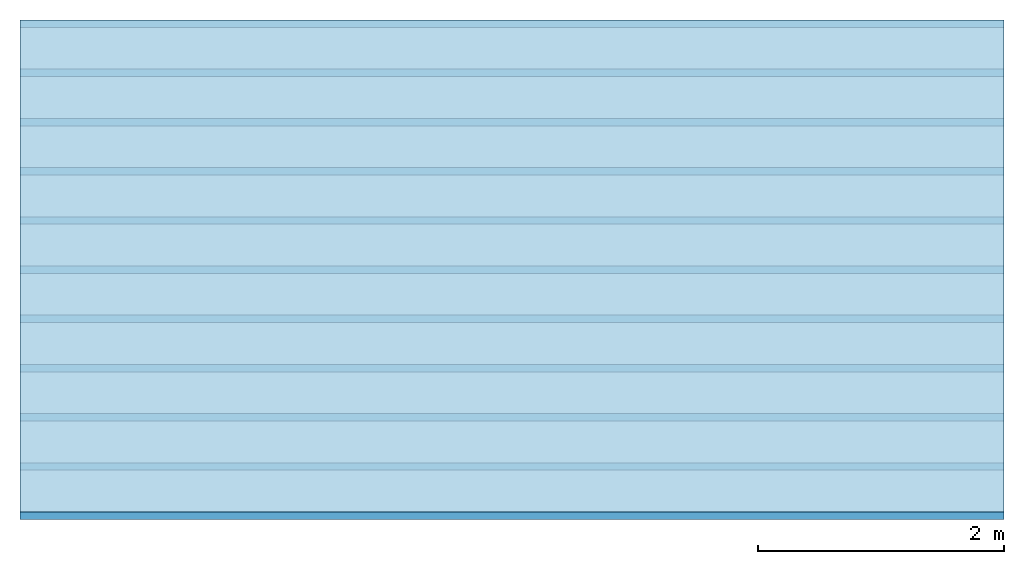
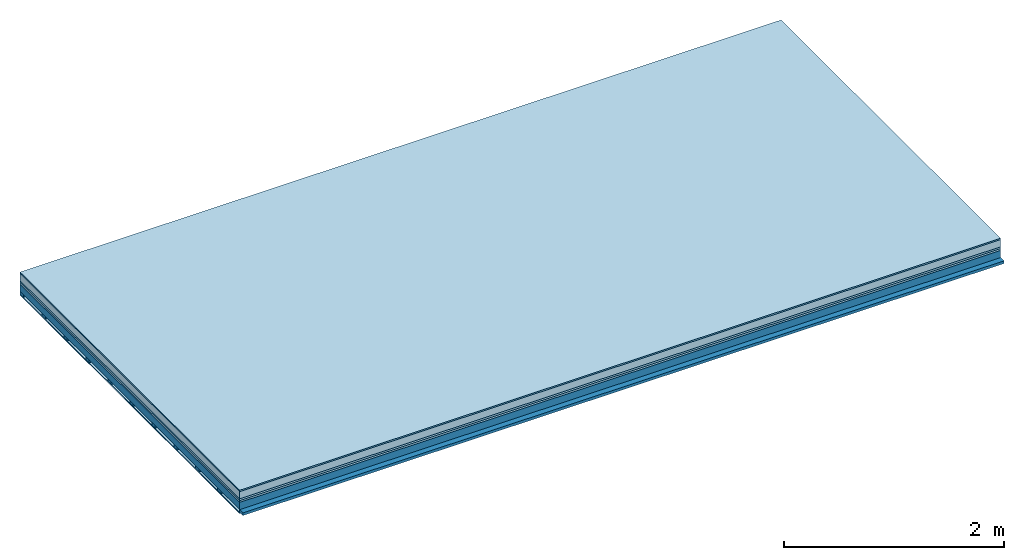
# One storey: 6 plates, 2 members, 1 element without a shape of its own.
"""IFC4 building model written with IfcOpenShell, lengths in metres."""

from ifc_helpers import new_model, si_unit, derived_unit, direction, frame, frame_2d, origin, origin_with_axes, place, context, project, spatial, rectangle, extrude, material, layer, layer_set, type_object, element, aggregate, save


model = new_model("IFC4")

# Units and contexts
plan_context = context("Plan", 3, precision=1e-05, world=origin(), true_north=direction((0.0, 1.0)))
model_context = context("Model", 3, precision=1e-05, world=origin(), true_north=direction((0.0, 1.0)))
ifc_project = project(units=[si_unit("LENGTHUNIT", "METRE"), derived_unit("SOUNDPRESSUREUNIT", [(si_unit("PRESSUREUNIT", "PASCAL", prefix="MICRO"), 0)]), si_unit("ENERGYUNIT", "JOULE", prefix="MEGA"), si_unit("MASSUNIT", "GRAM", prefix="KILO"), derived_unit("THERMALTRANSMITTANCEUNIT", [(si_unit("POWERUNIT", "WATT"), 1), (si_unit("AREAUNIT", "SQUARE_METRE"), -1), (si_unit("THERMODYNAMICTEMPERATUREUNIT", "KELVIN"), -1)]), derived_unit("AREADENSITYUNIT", [(si_unit("MASSUNIT", "GRAM", prefix="KILO"), 1), (si_unit("AREAUNIT", "SQUARE_METRE"), -1)]), derived_unit("USERDEFINED", [(si_unit("ENERGYUNIT", "JOULE", prefix="MEGA"), 1), (si_unit("AREAUNIT", "SQUARE_METRE"), -1)])], contexts=[plan_context, model_context])

# Site, building, storey
site = spatial("IfcSite", under=ifc_project)
building_placement = place(None, origin())
building = spatial("IfcBuilding", under=site, at=building_placement)
storey_placement = place(building_placement, origin())
storey = spatial("IfcBuildingStorey", under=building, at=storey_placement)

# Slab, members, plates
ifc_material_1 = material(Category="11.013")
ifc_layer_1 = layer(ifc_material_1, 0.015, Name="Flooring")
ifc_material_2 = material(Name="Cement screed", Category="04.006")
ifc_layer_2 = layer(ifc_material_2, 0.08, Name="On-material")
ifc_material_3 = material(Name="Wood fiber generic product", Category="10.009")
ifc_layer_3 = layer(ifc_material_3, 0.02, Name="Impact sound insulation")
ifc_material_4 = material(Category="10.004")
ifc_layer_4 = layer(ifc_material_4, 0.02, Name="Additional insulation")
ifc_material_5 = material(Name="no composite action")
ifc_layer_5 = layer(ifc_material_5, 0.0, Name="Bond")
ifc_layer_6 = layer(None, 0.08, Name="Supporting structure")
ifc_material_6 = material(Name="of the art")
ifc_layer_7 = layer(ifc_material_6, 0.0, Name="Bond")
ifc_layer_8 = layer(None, 0.03, Name="Battens / profiles")
ifc_material_7 = material(Name="Plasterboard type A", Category="03.008")
ifc_layer_9 = layer(ifc_material_7, 0.0125, Name="Ceiling covering 1st layer")
ifc_material_8 = material(Category="04.001")
ifc_layer_10 = layer(ifc_material_8, 0.003, Name="Surface / treatment")
ifc_layer_set = layer_set([ifc_layer_1, ifc_layer_2, ifc_layer_3, ifc_layer_4, ifc_layer_5, ifc_layer_6, ifc_layer_7, ifc_layer_8, ifc_layer_9, ifc_layer_10])
slab_type = type_object("IfcSlabType", Name="A2139", PredefinedType="NOTDEFINED", material=ifc_layer_set)
slab_placement = place(None, frame((0.0, 0.0, 0.0), z_axis=(0.0, 0.0, -1.0), x_axis=(1.0, 0.0, 0.0)))
slab = element("IfcSlab", 1, at=slab_placement, inside=storey, type_object=slab_type, material=ifc_layer_set, Name="Slab #1")
ifc_material_9 = material(Name="Solid timber panel")
member_1_placement = place(slab_placement, origin())
member_1 = element("IfcMember", 2, at=member_1_placement, material=ifc_material_9, Name="Supporting structure", context=plan_context, shape_type="SweptSolid", body=[
    extrude(rectangle(XDim=1.0, YDim=0.08, at=frame_2d((0.5, 0.04), x_axis=(1.0, 0.0))), frame((0.0, 4.0, 0.135), z_axis=(0.0, -1.0, 0.0), x_axis=(1.0, 0.0, 0.0)), (0.0, 0.0, 1.0), 4.0),
    extrude(rectangle(XDim=1.0, YDim=0.08, at=frame_2d((0.5, 0.04), x_axis=(1.0, 0.0))), frame((1.0, 4.0, 0.135), z_axis=(0.0, -1.0, 0.0), x_axis=(1.0, 0.0, 0.0)), (0.0, 0.0, 1.0), 4.0),
    extrude(rectangle(XDim=1.0, YDim=0.08, at=frame_2d((0.5, 0.04), x_axis=(1.0, 0.0))), frame((2.0, 4.0, 0.135), z_axis=(0.0, -1.0, 0.0), x_axis=(1.0, 0.0, 0.0)), (0.0, 0.0, 1.0), 4.0),
    extrude(rectangle(XDim=1.0, YDim=0.08, at=frame_2d((0.5, 0.04), x_axis=(1.0, 0.0))), frame((3.0, 4.0, 0.135), z_axis=(0.0, -1.0, 0.0), x_axis=(1.0, 0.0, 0.0)), (0.0, 0.0, 1.0), 4.0),
    extrude(rectangle(XDim=1.0, YDim=0.08, at=frame_2d((0.5, 0.04), x_axis=(1.0, 0.0))), frame((4.0, 4.0, 0.135), z_axis=(0.0, -1.0, 0.0), x_axis=(1.0, 0.0, 0.0)), (0.0, 0.0, 1.0), 4.0),
    extrude(rectangle(XDim=1.0, YDim=0.08, at=frame_2d((0.5, 0.04), x_axis=(1.0, 0.0))), frame((5.0, 4.0, 0.135), z_axis=(0.0, -1.0, 0.0), x_axis=(1.0, 0.0, 0.0)), (0.0, 0.0, 1.0), 4.0),
    extrude(rectangle(XDim=1.0, YDim=0.08, at=frame_2d((0.5, 0.04), x_axis=(1.0, 0.0))), frame((6.0, 4.0, 0.135), z_axis=(0.0, -1.0, 0.0), x_axis=(1.0, 0.0, 0.0)), (0.0, 0.0, 1.0), 4.0),
    extrude(rectangle(XDim=1.0, YDim=0.08, at=frame_2d((0.5, 0.04), x_axis=(1.0, 0.0))), frame((7.0, 4.0, 0.135), z_axis=(0.0, -1.0, 0.0), x_axis=(1.0, 0.0, 0.0)), (0.0, 0.0, 1.0), 4.0),
])
ifc_material_10 = material()
member_2_placement = place(slab_placement, origin())
member_2 = element("IfcMember", 3, at=member_2_placement, material=ifc_material_10, Name="Battens / profiles", context=plan_context, shape_type="SweptSolid", body=[
    extrude(rectangle(XDim=0.06, YDim=0.03, at=frame_2d((0.03, 0.015), x_axis=(1.0, 0.0))), frame((0.0, 0.0, 0.215), z_axis=(1.0, 0.0, 0.0), x_axis=(0.0, 1.0, 0.0)), (0.0, 0.0, 1.0), 8.0),
    extrude(rectangle(XDim=0.06, YDim=0.03, at=frame_2d((0.03, 0.015), x_axis=(1.0, 0.0))), frame((0.0, 0.4, 0.215), z_axis=(1.0, 0.0, 0.0), x_axis=(0.0, 1.0, 0.0)), (0.0, 0.0, 1.0), 8.0),
    extrude(rectangle(XDim=0.06, YDim=0.03, at=frame_2d((0.03, 0.015), x_axis=(1.0, 0.0))), frame((0.0, 0.8, 0.215), z_axis=(1.0, 0.0, 0.0), x_axis=(0.0, 1.0, 0.0)), (0.0, 0.0, 1.0), 8.0),
    extrude(rectangle(XDim=0.06, YDim=0.03, at=frame_2d((0.03, 0.015), x_axis=(1.0, 0.0))), frame((0.0, 1.2, 0.215), z_axis=(1.0, 0.0, 0.0), x_axis=(0.0, 1.0, 0.0)), (0.0, 0.0, 1.0), 8.0),
    extrude(rectangle(XDim=0.06, YDim=0.03, at=frame_2d((0.03, 0.015), x_axis=(1.0, 0.0))), frame((0.0, 1.6, 0.215), z_axis=(1.0, 0.0, 0.0), x_axis=(0.0, 1.0, 0.0)), (0.0, 0.0, 1.0), 8.0),
    extrude(rectangle(XDim=0.06, YDim=0.03, at=frame_2d((0.03, 0.015), x_axis=(1.0, 0.0))), frame((0.0, 2.0, 0.215), z_axis=(1.0, 0.0, 0.0), x_axis=(0.0, 1.0, 0.0)), (0.0, 0.0, 1.0), 8.0),
    extrude(rectangle(XDim=0.06, YDim=0.03, at=frame_2d((0.03, 0.015), x_axis=(1.0, 0.0))), frame((0.0, 2.4, 0.215), z_axis=(1.0, 0.0, 0.0), x_axis=(0.0, 1.0, 0.0)), (0.0, 0.0, 1.0), 8.0),
    extrude(rectangle(XDim=0.06, YDim=0.03, at=frame_2d((0.03, 0.015), x_axis=(1.0, 0.0))), frame((0.0, 2.8, 0.215), z_axis=(1.0, 0.0, 0.0), x_axis=(0.0, 1.0, 0.0)), (0.0, 0.0, 1.0), 8.0),
    extrude(rectangle(XDim=0.06, YDim=0.03, at=frame_2d((0.03, 0.015), x_axis=(1.0, 0.0))), frame((0.0, 3.2, 0.215), z_axis=(1.0, 0.0, 0.0), x_axis=(0.0, 1.0, 0.0)), (0.0, 0.0, 1.0), 8.0),
    extrude(rectangle(XDim=0.06, YDim=0.03, at=frame_2d((0.03, 0.015), x_axis=(1.0, 0.0))), frame((0.0, 3.6, 0.215), z_axis=(1.0, 0.0, 0.0), x_axis=(0.0, 1.0, 0.0)), (0.0, 0.0, 1.0), 8.0),
    extrude(rectangle(XDim=0.06, YDim=0.03, at=frame_2d((0.03, 0.015), x_axis=(1.0, 0.0))), frame((0.0, 4.0, 0.215), z_axis=(1.0, 0.0, 0.0), x_axis=(0.0, 1.0, 0.0)), (0.0, 0.0, 1.0), 8.0),
])
plate_1_placement = place(slab_placement, origin())
plate_1 = element("IfcPlate", 4, at=plate_1_placement, material=ifc_material_1, Name="Flooring", context=plan_context, shape_type="SweptSolid", body=[
    extrude(rectangle(XDim=8.0, YDim=4.0, at=frame_2d((4.0, 2.0), x_axis=(1.0, 0.0))), origin_with_axes(), (0.0, 0.0, 1.0), 0.015),
])
plate_2_placement = place(slab_placement, origin())
plate_2 = element("IfcPlate", 5, at=plate_2_placement, material=ifc_material_2, Name="On-material", context=plan_context, shape_type="SweptSolid", body=[
    extrude(rectangle(XDim=8.0, YDim=4.0, at=frame_2d((4.0, 2.0), x_axis=(1.0, 0.0))), frame((0.0, 0.0, 0.015), z_axis=(0.0, 0.0, 1.0), x_axis=(1.0, 0.0, 0.0)), (0.0, 0.0, 1.0), 0.08),
])
plate_3_placement = place(slab_placement, origin())
plate_3 = element("IfcPlate", 6, at=plate_3_placement, material=ifc_material_3, Name="Impact sound insulation", context=plan_context, shape_type="SweptSolid", body=[
    extrude(rectangle(XDim=8.0, YDim=4.0, at=frame_2d((4.0, 2.0), x_axis=(1.0, 0.0))), frame((0.0, 0.0, 0.095), z_axis=(0.0, 0.0, 1.0), x_axis=(1.0, 0.0, 0.0)), (0.0, 0.0, 1.0), 0.02),
])
plate_4_placement = place(slab_placement, origin())
plate_4 = element("IfcPlate", 7, at=plate_4_placement, material=ifc_material_4, Name="Additional insulation", context=plan_context, shape_type="SweptSolid", body=[
    extrude(rectangle(XDim=8.0, YDim=4.0, at=frame_2d((4.0, 2.0), x_axis=(1.0, 0.0))), frame((0.0, 0.0, 0.115), z_axis=(0.0, 0.0, 1.0), x_axis=(1.0, 0.0, 0.0)), (0.0, 0.0, 1.0), 0.02),
])
plate_5_placement = place(slab_placement, origin())
plate_5 = element("IfcPlate", 8, at=plate_5_placement, material=ifc_material_7, Name="Ceiling covering 1st layer", context=plan_context, shape_type="SweptSolid", body=[
    extrude(rectangle(XDim=8.0, YDim=4.0, at=frame_2d((4.0, 2.0), x_axis=(1.0, 0.0))), frame((0.0, 0.0, 0.245), z_axis=(0.0, 0.0, 1.0), x_axis=(1.0, 0.0, 0.0)), (0.0, 0.0, 1.0), 0.0125),
])
plate_6_placement = place(slab_placement, origin())
plate_6 = element("IfcPlate", 9, at=plate_6_placement, material=ifc_material_8, Name="Surface / treatment", context=plan_context, shape_type="SweptSolid", body=[
    extrude(rectangle(XDim=8.0, YDim=4.0, at=frame_2d((4.0, 2.0), x_axis=(1.0, 0.0))), frame((0.0, 0.0, 0.2575), z_axis=(0.0, 0.0, 1.0), x_axis=(1.0, 0.0, 0.0)), (0.0, 0.0, 1.0), 0.003),
])
aggregate(slab, [plate_1, plate_2, plate_3, plate_4, member_1, member_2, plate_5, plate_6])

save(model, "model.ifc")
